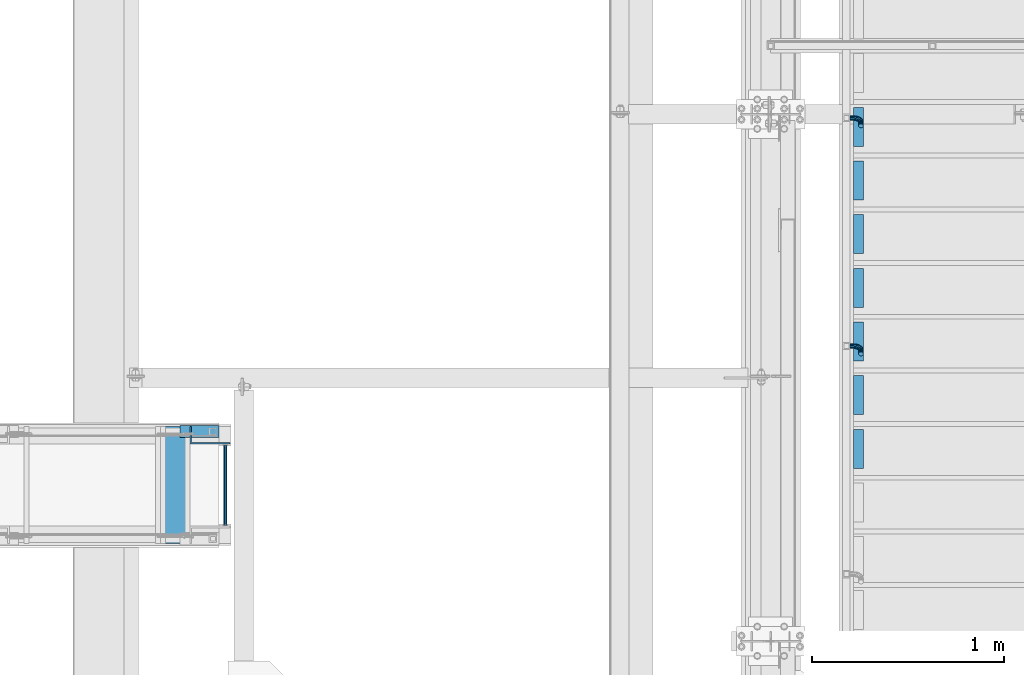
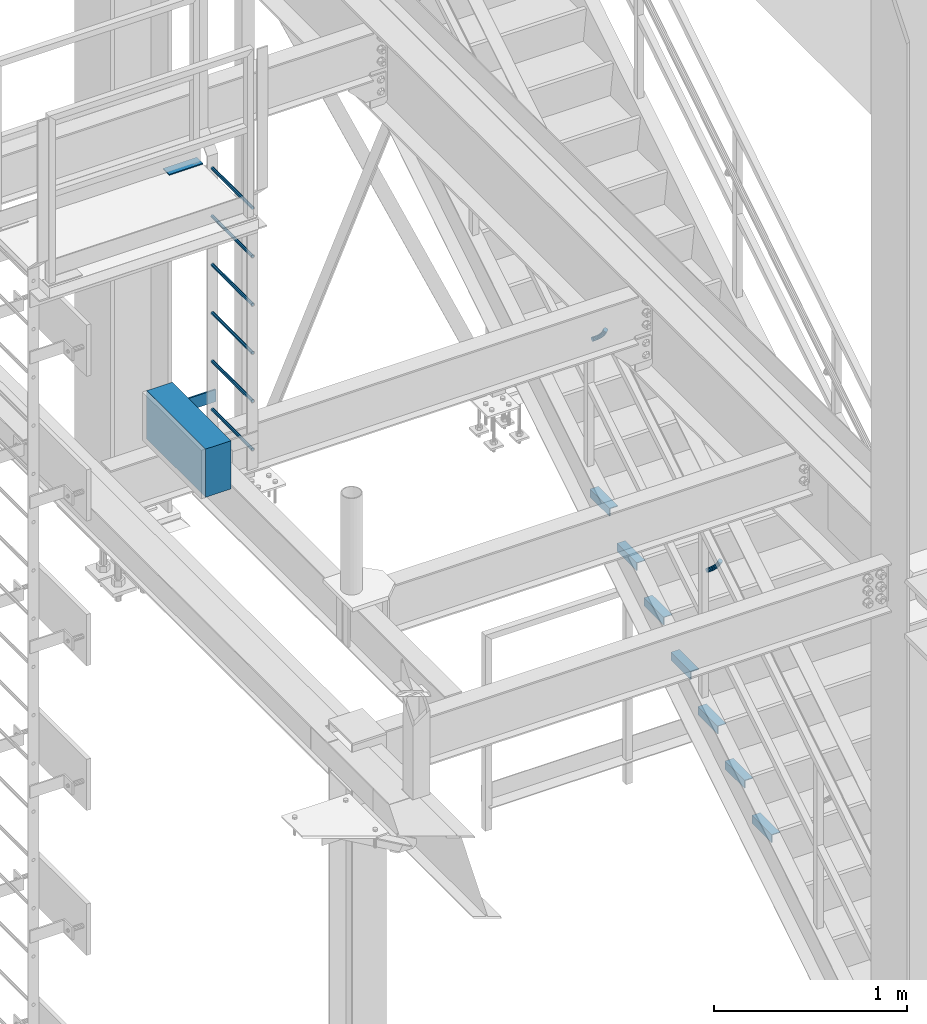
# One storey, part 2016 of 3843: 18 beams, 5 elements without a shape of their own.
"""IFC2X3 building model written with IfcOpenShell, lengths in millimetres."""

from ifc_helpers import new_model, si_unit, frame, origin_with_axes, place, context, subcontext, project, spatial, faceted_brep, material, type_object, element, aggregate, save


model = new_model("IFC2X3")

# Units and contexts
model_context = context("Model", 3, precision=1e-05, world=origin_with_axes())
body_context = subcontext(model_context, "Body", "Model", "MODEL_VIEW")
ifc_project = project(units=[si_unit("LENGTHUNIT", "METRE", prefix="MILLI"), si_unit("AREAUNIT", "SQUARE_METRE"), si_unit("VOLUMEUNIT", "CUBIC_METRE"), si_unit("MASSUNIT", "GRAM", prefix="KILO"), si_unit("TIMEUNIT", "SECOND"), si_unit("PLANEANGLEUNIT", "RADIAN"), si_unit("SOLIDANGLEUNIT", "STERADIAN"), si_unit("THERMODYNAMICTEMPERATUREUNIT", "DEGREE_CELSIUS"), si_unit("LUMINOUSINTENSITYUNIT", "LUMEN")], contexts=[model_context])

# Site, building, storey
site_placement = place(None, origin_with_axes())
site = spatial("IfcSite", under=ifc_project, at=site_placement, CompositionType="ELEMENT")
building_placement = place(site_placement, origin_with_axes())
building = spatial("IfcBuilding", under=site, at=building_placement, Name="Undefined", CompositionType="ELEMENT")
storey_placement = place(building_placement, origin_with_axes())
storey = spatial("IfcBuildingStorey", under=building, at=storey_placement, Name="Undefined", CompositionType="ELEMENT", Elevation=0.0)

# Assembly, beam
assembly_1_placement = place(storey_placement, origin_with_axes())
assembly_1 = element("IfcElementAssembly", 1, at=assembly_1_placement, inside=storey, Name="BEAM", AssemblyPlace="NOTDEFINED", PredefinedType="REINFORCEMENT_UNIT")
ifc_material_1 = material(Name="CONCRETE/5000")
beam_type_1 = type_object("IfcBeamType", PredefinedType="NOTDEFINED")
beam_1_placement = place(assembly_1_placement, frame((33476.6950414921, 27495.4999999999, 35255.2009490967), z_axis=(0.0, 0.0, 1.0), x_axis=(0.0, 1.0, 0.0)))
beam_1 = element("IfcBeam", 2, at=beam_1_placement, type_object=beam_type_1, material=ifc_material_1, Name="BEAM", context=body_context, shape_type="Brep", body=[
    faceted_brep([(0.0, 76.1999999999971, -152.400000000001), (0.0, 76.1999999999971, 152.400000000001), (609.599999999507, 76.1999999999971, 152.400000000001), (609.599999999507, 76.1999999999971, -152.400000000001), (0.0, -76.1999999999971, 152.400000000001), (609.599999999507, -76.1999999999971, 152.400000000001), (0.0, -76.1999999999971, -152.400000000001), (609.599999999507, -76.1999999999971, -152.400000000001)], [[[0, 1, 2, 3]], [[1, 4, 5, 2]], [[4, 6, 7, 5]], [[6, 0, 3, 7]], [[5, 7, 3, 2]], [[6, 4, 1, 0]]]),
])
aggregate(assembly_1, [beam_1])

assembly_2_placement = place(storey_placement, origin_with_axes())
assembly_2 = element("IfcElementAssembly", 3, at=assembly_2_placement, inside=storey, Name="LADDER", AssemblyPlace="NOTDEFINED", PredefinedType="RIGID_FRAME")
ifc_material_2 = material(Name="STEEL/A36")
beam_type_2 = type_object("IfcBeamType", PredefinedType="NOTDEFINED")
beam_2_placement = place(assembly_2_placement, frame((33761.4528544921, 28017.7874999999, 35306.0009490967), z_axis=(0.0, 0.0, 1.0), x_axis=(-1.0, 0.0, 0.0)))
beam_2 = element("IfcBeam", 4, at=beam_2_placement, type_object=beam_type_2, material=ifc_material_2, Name="BENT_PLATE", context=body_context, shape_type="Brep", body=[
    faceted_brep([(0.0, -4.76250000000073, -38.0999999999985), (0.0, -4.76250000000073, 38.0999999999985), (0.0, 4.76250000000073, 38.0999999999985), (0.0, 4.76250000000073, -38.0999999999985), (208.557813000007, 4.76249999999345, 38.0999999999985), (208.557813000007, 4.76249999999345, -38.0999999999985), (199.032813000013, -4.762500000008, -38.0999999999985), (199.032813000013, -4.762500000008, 38.0999999999985), (208.557813000007, -87.3124999995016, 38.0999999999985), (208.557813000007, -87.3124999995016, -38.0999999999985), (199.032813000013, -87.3124999995016, 38.0999999999985), (199.032813000013, -87.3124999995016, -38.0999999999985)], [[[0, 1, 2, 3]], [[3, 2, 4, 5]], [[1, 0, 6, 7]], [[5, 4, 8, 9]], [[4, 2, 1, 7, 10, 8]], [[7, 6, 11, 10]], [[6, 0, 3, 5, 9, 11]], [[10, 11, 9, 8]]]),
])

# Assembly, beams
assembly_3_placement = place(storey_placement, origin_with_axes())
assembly_3 = element("IfcElementAssembly", 5, at=assembly_3_placement, inside=storey, Name="STAIR", AssemblyPlace="NOTDEFINED", PredefinedType="RIGID_FRAME")
beam_type_3 = type_object("IfcBeamType", Name="L2X2X3/16", PredefinedType="NOTDEFINED")
beam_3_placement = place(assembly_3_placement, frame((37033.1999999894, 29563.5169176273, 32490.6821428628), z_axis=(1.0, 0.0, 0.0), x_axis=(0.0, 1.0, 0.0)))
beam_3 = element("IfcBeam", 6, at=beam_3_placement, type_object=beam_type_3, material=ifc_material_2, Name="ANGLE", ObjectType="L2X2X3/16", context=body_context, shape_type="Brep", body=[
    faceted_brep([(0.0, 25.4000000000015, -25.4000000000015), (0.0, 25.4000000000015, 25.4000000000015), (203.199999999997, 25.4000000000015, 25.4000000000015), (203.199999999997, 25.4000000000015, -25.4000000000015), (0.0, 20.6375000000007, 25.4000000000015), (203.199999999997, 20.6375000000007, 25.4000000000015), (0.0, 20.6375000000007, -20.6375000000007), (203.199999999997, 20.6375000000007, -20.6375000000007), (0.0, -25.4000000000015, -20.6375000000007), (203.199999999997, -25.4000000000015, -20.6375000000007), (0.0, -25.4000000000015, -25.4000000000015), (203.199999999997, -25.4000000000015, -25.4000000000015)], [[[0, 1, 2, 3]], [[1, 4, 5, 2]], [[4, 6, 7, 5]], [[6, 8, 9, 7]], [[8, 10, 11, 9]], [[10, 0, 3, 11]], [[5, 7, 9, 11, 3, 2]], [[10, 8, 6, 4, 1, 0]]]),
])
beam_4_placement = place(assembly_3_placement, frame((37033.1999999894, 29284.1169176273, 32316.5107142914), z_axis=(1.0, 0.0, 0.0), x_axis=(0.0, 1.0, 0.0)))
beam_4 = element("IfcBeam", 7, at=beam_4_placement, type_object=beam_type_3, material=ifc_material_2, Name="ANGLE", ObjectType="L2X2X3/16", context=body_context, shape_type="Brep", body=[
    faceted_brep([(0.0, 25.4000000000015, -25.4000000000015), (0.0, 25.4000000000015, 25.4000000000015), (203.199999999997, 25.4000000000015, 25.4000000000015), (203.199999999997, 25.4000000000015, -25.4000000000015), (0.0, 20.6375000000007, 25.4000000000015), (203.199999999997, 20.6375000000007, 25.4000000000015), (0.0, 20.6375000000007, -20.6375000000007), (203.199999999997, 20.6375000000007, -20.6375000000007), (0.0, -25.4000000000015, -20.6375000000007), (203.199999999997, -25.4000000000015, -20.6375000000007), (0.0, -25.4000000000015, -25.4000000000015), (203.199999999997, -25.4000000000015, -25.4000000000015)], [[[0, 1, 2, 3]], [[1, 4, 5, 2]], [[4, 6, 7, 5]], [[6, 8, 9, 7]], [[8, 10, 11, 9]], [[10, 0, 3, 11]], [[5, 7, 9, 11, 3, 2]], [[10, 8, 6, 4, 1, 0]]]),
])
beam_5_placement = place(assembly_3_placement, frame((37033.1999999894, 29004.7169176273, 32142.3392857199), z_axis=(1.0, 0.0, 0.0), x_axis=(0.0, 1.0, 0.0)))
beam_5 = element("IfcBeam", 8, at=beam_5_placement, type_object=beam_type_3, material=ifc_material_2, Name="ANGLE", ObjectType="L2X2X3/16", context=body_context, shape_type="Brep", body=[
    faceted_brep([(0.0, 25.4000000000015, -25.4000000000015), (0.0, 25.4000000000015, 25.4000000000015), (203.199999999997, 25.4000000000015, 25.4000000000015), (203.199999999997, 25.4000000000015, -25.4000000000015), (0.0, 20.6375000000007, 25.4000000000015), (203.199999999997, 20.6375000000007, 25.4000000000015), (0.0, 20.6375000000007, -20.6375000000007), (203.199999999997, 20.6375000000007, -20.6375000000007), (0.0, -25.4000000000015, -20.6375000000007), (203.199999999997, -25.4000000000015, -20.6375000000007), (0.0, -25.4000000000015, -25.4000000000015), (203.199999999997, -25.4000000000015, -25.4000000000015)], [[[0, 1, 2, 3]], [[1, 4, 5, 2]], [[4, 6, 7, 5]], [[6, 8, 9, 7]], [[8, 10, 11, 9]], [[10, 0, 3, 11]], [[5, 7, 9, 11, 3, 2]], [[10, 8, 6, 4, 1, 0]]]),
])
beam_6_placement = place(assembly_3_placement, frame((37033.1999999894, 28725.3169176272, 31968.1678571485), z_axis=(1.0, 0.0, 0.0), x_axis=(0.0, 1.0, 0.0)))
beam_6 = element("IfcBeam", 9, at=beam_6_placement, type_object=beam_type_3, material=ifc_material_2, Name="ANGLE", ObjectType="L2X2X3/16", context=body_context, shape_type="Brep", body=[
    faceted_brep([(0.0, 25.4000000000015, -25.4000000000015), (0.0, 25.4000000000015, 25.4000000000015), (203.199999999997, 25.4000000000015, 25.4000000000015), (203.199999999997, 25.4000000000015, -25.4000000000015), (0.0, 20.6375000000007, 25.4000000000015), (203.199999999997, 20.6375000000007, 25.4000000000015), (0.0, 20.6375000000007, -20.6375000000007), (203.199999999997, 20.6375000000007, -20.6375000000007), (0.0, -25.4000000000015, -20.6375000000007), (203.199999999997, -25.4000000000015, -20.6375000000007), (0.0, -25.4000000000015, -25.4000000000015), (203.199999999997, -25.4000000000015, -25.4000000000015)], [[[0, 1, 2, 3]], [[1, 4, 5, 2]], [[4, 6, 7, 5]], [[6, 8, 9, 7]], [[8, 10, 11, 9]], [[10, 0, 3, 11]], [[5, 7, 9, 11, 3, 2]], [[10, 8, 6, 4, 1, 0]]]),
])
beam_7_placement = place(assembly_3_placement, frame((37033.1999999894, 28445.9169176272, 31793.9964285771), z_axis=(1.0, 0.0, 0.0), x_axis=(0.0, 1.0, 0.0)))
beam_7 = element("IfcBeam", 10, at=beam_7_placement, type_object=beam_type_3, material=ifc_material_2, Name="ANGLE", ObjectType="L2X2X3/16", context=body_context, shape_type="Brep", body=[
    faceted_brep([(0.0, 25.4000000000015, -25.4000000000015), (0.0, 25.4000000000015, 25.4000000000015), (203.199999999997, 25.4000000000015, 25.4000000000015), (203.199999999997, 25.4000000000015, -25.4000000000015), (0.0, 20.6375000000007, 25.4000000000015), (203.199999999997, 20.6375000000007, 25.4000000000015), (0.0, 20.6375000000007, -20.6375000000007), (203.199999999997, 20.6375000000007, -20.6375000000007), (0.0, -25.4000000000015, -20.6375000000007), (203.199999999997, -25.4000000000015, -20.6375000000007), (0.0, -25.4000000000015, -25.4000000000015), (203.199999999997, -25.4000000000015, -25.4000000000015)], [[[0, 1, 2, 3]], [[1, 4, 5, 2]], [[4, 6, 7, 5]], [[6, 8, 9, 7]], [[8, 10, 11, 9]], [[10, 0, 3, 11]], [[5, 7, 9, 11, 3, 2]], [[10, 8, 6, 4, 1, 0]]]),
])
beam_8_placement = place(assembly_3_placement, frame((37033.1999999894, 28166.5169176272, 31619.8250000057), z_axis=(1.0, 0.0, 0.0), x_axis=(0.0, 1.0, 0.0)))
beam_8 = element("IfcBeam", 11, at=beam_8_placement, type_object=beam_type_3, material=ifc_material_2, Name="ANGLE", ObjectType="L2X2X3/16", context=body_context, shape_type="Brep", body=[
    faceted_brep([(0.0, 25.4000000000015, -25.4000000000015), (0.0, 25.4000000000015, 25.4000000000015), (203.199999999997, 25.4000000000015, 25.4000000000015), (203.199999999997, 25.4000000000015, -25.4000000000015), (0.0, 20.6375000000007, 25.4000000000015), (203.199999999997, 20.6375000000007, 25.4000000000015), (0.0, 20.6375000000007, -20.6375000000007), (203.199999999997, 20.6375000000007, -20.6375000000007), (0.0, -25.4000000000015, -20.6375000000007), (203.199999999997, -25.4000000000015, -20.6375000000007), (0.0, -25.4000000000015, -25.4000000000015), (203.199999999997, -25.4000000000015, -25.4000000000015)], [[[0, 1, 2, 3]], [[1, 4, 5, 2]], [[4, 6, 7, 5]], [[6, 8, 9, 7]], [[8, 10, 11, 9]], [[10, 0, 3, 11]], [[5, 7, 9, 11, 3, 2]], [[10, 8, 6, 4, 1, 0]]]),
])
beam_9_placement = place(assembly_3_placement, frame((37033.1999999894, 27887.1169176272, 31445.6535714342), z_axis=(1.0, 0.0, 0.0), x_axis=(0.0, 1.0, 0.0)))
beam_9 = element("IfcBeam", 12, at=beam_9_placement, type_object=beam_type_3, material=ifc_material_2, Name="ANGLE", ObjectType="L2X2X3/16", context=body_context, shape_type="Brep", body=[
    faceted_brep([(0.0, 25.4000000000015, -25.4000000000015), (0.0, 25.4000000000015, 25.4000000000015), (203.199999999997, 25.4000000000015, 25.4000000000015), (203.199999999997, 25.4000000000015, -25.4000000000015), (0.0, 20.6375000000007, 25.4000000000015), (203.199999999997, 20.6375000000007, 25.4000000000015), (0.0, 20.6375000000007, -20.6375000000007), (203.199999999997, 20.6375000000007, -20.6375000000007), (0.0, -25.4000000000015, -20.6375000000007), (203.199999999997, -25.4000000000015, -20.6375000000007), (0.0, -25.4000000000015, -25.4000000000015), (203.199999999997, -25.4000000000015, -25.4000000000015)], [[[0, 1, 2, 3]], [[1, 4, 5, 2]], [[4, 6, 7, 5]], [[6, 8, 9, 7]], [[8, 10, 11, 9]], [[10, 0, 3, 11]], [[5, 7, 9, 11, 3, 2]], [[10, 8, 6, 4, 1, 0]]]),
])
aggregate(assembly_3, [beam_3, beam_4, beam_5, beam_6, beam_7, beam_8, beam_9])

# Beam
ifc_material_3 = material(Name="STEEL/A572-50")
beam_type_4 = type_object("IfcBeamType", PredefinedType="NOTDEFINED")
beam_10_placement = place(assembly_2_placement, frame((33736.4390258789, 27590.7499999999, 35231.5155151367), z_axis=(-1.0, 0.0, 0.0), x_axis=(0.0, 1.0, 0.0)))
beam_10 = element("IfcBeam", 13, at=beam_10_placement, type_object=beam_type_4, material=ifc_material_3, Name="RUNG", context=body_context, shape_type="Brep", body=[
    faceted_brep([(0.0, -9.52500000000146, 0.0), (0.0, -6.73519209080405, -6.73519209079677), (419.100000000006, -6.73519209080405, -6.73519209079677), (419.100000000006, -9.52500000000146, 0.0), (2.95075507493764e-12, 2.91322521661641e-12, -9.52499961853027), (419.100000000006, 0.0, -9.52499999999418), (0.0, 6.73519209080405, -6.73519209079677), (419.100000000006, 6.73519209080405, -6.73519209079677), (0.0, 9.52500000000146, 0.0), (419.100000000006, 9.52500000000146, 0.0), (0.0, 6.73519209080405, 6.73519209079677), (419.100000000006, 6.73519209080405, 6.73519209079677), (-9.87109982941227e-13, 2.91322521661641e-12, 9.52499961853027), (419.100000000006, 0.0, 9.52499999999418), (0.0, -6.73519209080405, 6.73519209079677), (419.100000000006, -6.73519209080405, 6.73519209079677)], [[[0, 1, 2, 3]], [[1, 4, 5, 2]], [[4, 6, 7, 5]], [[6, 8, 9, 7]], [[8, 10, 11, 9]], [[10, 12, 13, 11]], [[12, 14, 15, 13]], [[14, 0, 3, 15]], [[5, 7, 9, 11, 13, 15, 3, 2]], [[14, 12, 10, 8, 6, 4, 1, 0]]]),
])

beam_11_placement = place(assembly_2_placement, frame((33736.4390258789, 27590.7499999999, 35841.1155151367), z_axis=(-1.0, 0.0, 0.0), x_axis=(0.0, 1.0, 0.0)))
beam_11 = element("IfcBeam", 14, at=beam_11_placement, type_object=beam_type_4, material=ifc_material_3, Name="RUNG", context=body_context, shape_type="Brep", body=[
    faceted_brep([(0.0, -9.52500000000146, 0.0), (0.0, -6.73519209080405, -6.73519209079677), (419.100000000006, -6.73519209080405, -6.73519209079677), (419.100000000006, -9.52500000000146, 0.0), (2.95075507493764e-12, 2.91322521661641e-12, -9.52499961853027), (419.100000000006, 0.0, -9.52499999999418), (0.0, 6.73519209080405, -6.73519209079677), (419.100000000006, 6.73519209080405, -6.73519209079677), (0.0, 9.52500000000146, 0.0), (419.100000000006, 9.52500000000146, 0.0), (0.0, 6.73519209080405, 6.73519209079677), (419.100000000006, 6.73519209080405, 6.73519209079677), (-9.87109982941227e-13, 2.91322521661641e-12, 9.52499961853027), (419.100000000006, 0.0, 9.52499999999418), (0.0, -6.73519209080405, 6.73519209079677), (419.100000000006, -6.73519209080405, 6.73519209079677)], [[[0, 1, 2, 3]], [[1, 4, 5, 2]], [[4, 6, 7, 5]], [[6, 8, 9, 7]], [[8, 10, 11, 9]], [[10, 12, 13, 11]], [[12, 14, 15, 13]], [[14, 0, 3, 15]], [[5, 7, 9, 11, 13, 15, 3, 2]], [[14, 12, 10, 8, 6, 4, 1, 0]]]),
])

beam_12_placement = place(assembly_2_placement, frame((33736.4390258789, 27590.7499999999, 35536.3155151367), z_axis=(-1.0, 0.0, 0.0), x_axis=(0.0, 1.0, 0.0)))
beam_12 = element("IfcBeam", 15, at=beam_12_placement, type_object=beam_type_4, material=ifc_material_3, Name="RUNG", context=body_context, shape_type="Brep", body=[
    faceted_brep([(0.0, -9.52500000000146, 0.0), (0.0, -6.73519209080405, -6.73519209079677), (419.100000000006, -6.73519209080405, -6.73519209079677), (419.100000000006, -9.52500000000146, 0.0), (2.95075507493764e-12, 2.91322521661641e-12, -9.52499961853027), (419.100000000006, 0.0, -9.52499999999418), (0.0, 6.73519209080405, -6.73519209079677), (419.100000000006, 6.73519209080405, -6.73519209079677), (0.0, 9.52500000000146, 0.0), (419.100000000006, 9.52500000000146, 0.0), (0.0, 6.73519209080405, 6.73519209079677), (419.100000000006, 6.73519209080405, 6.73519209079677), (-9.87109982941227e-13, 2.91322521661641e-12, 9.52499961853027), (419.100000000006, 0.0, 9.52499999999418), (0.0, -6.73519209080405, 6.73519209079677), (419.100000000006, -6.73519209080405, 6.73519209079677)], [[[0, 1, 2, 3]], [[1, 4, 5, 2]], [[4, 6, 7, 5]], [[6, 8, 9, 7]], [[8, 10, 11, 9]], [[10, 12, 13, 11]], [[12, 14, 15, 13]], [[14, 0, 3, 15]], [[5, 7, 9, 11, 13, 15, 3, 2]], [[14, 12, 10, 8, 6, 4, 1, 0]]]),
])

beam_13_placement = place(assembly_2_placement, frame((33736.4390258789, 27590.7499999999, 36145.9155151367), z_axis=(-1.0, 0.0, 0.0), x_axis=(0.0, 1.0, 0.0)))
beam_13 = element("IfcBeam", 16, at=beam_13_placement, type_object=beam_type_4, material=ifc_material_3, Name="RUNG", context=body_context, shape_type="Brep", body=[
    faceted_brep([(0.0, -9.52500000000146, 0.0), (0.0, -6.73519209080405, -6.73519209079677), (419.100000000006, -6.73519209080405, -6.73519209079677), (419.100000000006, -9.52500000000146, 0.0), (2.95075507493764e-12, 2.91322521661641e-12, -9.52499961853027), (419.100000000006, 0.0, -9.52499999999418), (0.0, 6.73519209080405, -6.73519209079677), (419.100000000006, 6.73519209080405, -6.73519209079677), (0.0, 9.52500000000146, 0.0), (419.100000000006, 9.52500000000146, 0.0), (0.0, 6.73519209080405, 6.73519209079677), (419.100000000006, 6.73519209080405, 6.73519209079677), (-9.87109982941227e-13, 2.91322521661641e-12, 9.52499961853027), (419.100000000006, 0.0, 9.52499999999418), (0.0, -6.73519209080405, 6.73519209079677), (419.100000000006, -6.73519209080405, 6.73519209079677)], [[[0, 1, 2, 3]], [[1, 4, 5, 2]], [[4, 6, 7, 5]], [[6, 8, 9, 7]], [[8, 10, 11, 9]], [[10, 12, 13, 11]], [[12, 14, 15, 13]], [[14, 0, 3, 15]], [[5, 7, 9, 11, 13, 15, 3, 2]], [[14, 12, 10, 8, 6, 4, 1, 0]]]),
])

beam_14_placement = place(assembly_2_placement, frame((33736.4390258789, 27590.7499999999, 36450.7155151367), z_axis=(-1.0, 0.0, 0.0), x_axis=(0.0, 1.0, 0.0)))
beam_14 = element("IfcBeam", 17, at=beam_14_placement, type_object=beam_type_4, material=ifc_material_3, Name="RUNG", context=body_context, shape_type="Brep", body=[
    faceted_brep([(0.0, -9.52500000000146, 0.0), (0.0, -6.73519209080405, -6.73519209079677), (419.100000000006, -6.73519209080405, -6.73519209079677), (419.100000000006, -9.52500000000146, 0.0), (2.95075507493764e-12, 2.91322521661641e-12, -9.52499961853027), (419.100000000006, 0.0, -9.52499999999418), (0.0, 6.73519209080405, -6.73519209079677), (419.100000000006, 6.73519209080405, -6.73519209079677), (0.0, 9.52500000000146, 0.0), (419.100000000006, 9.52500000000146, 0.0), (0.0, 6.73519209080405, 6.73519209079677), (419.100000000006, 6.73519209080405, 6.73519209079677), (-9.87109982941227e-13, 2.91322521661641e-12, 9.52499961853027), (419.100000000006, 0.0, 9.52499999999418), (0.0, -6.73519209080405, 6.73519209079677), (419.100000000006, -6.73519209080405, 6.73519209079677)], [[[0, 1, 2, 3]], [[1, 4, 5, 2]], [[4, 6, 7, 5]], [[6, 8, 9, 7]], [[8, 10, 11, 9]], [[10, 12, 13, 11]], [[12, 14, 15, 13]], [[14, 0, 3, 15]], [[5, 7, 9, 11, 13, 15, 3, 2]], [[14, 12, 10, 8, 6, 4, 1, 0]]]),
])

beam_15_placement = place(assembly_2_placement, frame((33736.4390258789, 27590.7499999999, 36755.5155151367), z_axis=(-1.0, 0.0, 0.0), x_axis=(0.0, 1.0, 0.0)))
beam_15 = element("IfcBeam", 18, at=beam_15_placement, type_object=beam_type_4, material=ifc_material_3, Name="RUNG", context=body_context, shape_type="Brep", body=[
    faceted_brep([(0.0, -9.52500000000146, 0.0), (0.0, -6.73519209080405, -6.73519209079677), (419.100000000006, -6.73519209080405, -6.73519209079677), (419.100000000006, -9.52500000000146, 0.0), (2.95075507493764e-12, 2.91322521661641e-12, -9.52499961853027), (419.100000000006, 0.0, -9.52499999999418), (0.0, 6.73519209080405, -6.73519209079677), (419.100000000006, 6.73519209080405, -6.73519209079677), (0.0, 9.52500000000146, 0.0), (419.100000000006, 9.52500000000146, 0.0), (0.0, 6.73519209080405, 6.73519209079677), (419.100000000006, 6.73519209080405, 6.73519209079677), (-9.87109982941227e-13, 2.91322521661641e-12, 9.52499961853027), (419.100000000006, 0.0, 9.52499999999418), (0.0, -6.73519209080405, 6.73519209079677), (419.100000000006, -6.73519209080405, 6.73519209079677)], [[[0, 1, 2, 3]], [[1, 4, 5, 2]], [[4, 6, 7, 5]], [[6, 8, 9, 7]], [[8, 10, 11, 9]], [[10, 12, 13, 11]], [[12, 14, 15, 13]], [[14, 0, 3, 15]], [[5, 7, 9, 11, 13, 15, 3, 2]], [[14, 12, 10, 8, 6, 4, 1, 0]]]),
])

aggregate(assembly_2, [beam_2, beam_10, beam_11, beam_12, beam_13, beam_14, beam_15])

# Assembly, beam
assembly_4_placement = place(storey_placement, origin_with_axes())
assembly_4 = element("IfcElementAssembly", 19, at=assembly_4_placement, inside=storey, Name="RAIL", AssemblyPlace="NOTDEFINED", PredefinedType="RIGID_FRAME")
beam_type_5 = type_object("IfcBeamType", PredefinedType="NOTDEFINED")
beam_16_placement = place(assembly_4_placement, frame((33704.6093748092, 28079.6999999999, 36768.7510559082), z_axis=(0.0, -1.0, 0.0), x_axis=(-1.0, 0.0, 0.0)))
beam_16 = element("IfcBeam", 20, at=beam_16_placement, type_object=beam_type_5, material=ifc_material_2, context=body_context, shape_type="Brep", body=[
    faceted_brep([(0.0, 3.17500000000291, -31.75), (0.0, 3.17500000000291, 31.75), (203.199998088516, 3.17500000000291, 31.75), (203.199998088516, 3.17500000000291, -31.75), (0.0, -3.17500000000291, 31.75), (203.199998088516, -3.17500000000291, 31.75), (0.0, -3.17500000000291, -31.75), (203.199998088516, -3.17500000000291, -31.75)], [[[0, 1, 2, 3]], [[1, 4, 5, 2]], [[4, 6, 7, 5]], [[6, 0, 3, 7]], [[5, 7, 3, 2]], [[6, 4, 1, 0]]]),
])
aggregate(assembly_4, [beam_16])

# Assembly, beams
assembly_5_placement = place(storey_placement, origin_with_axes())
assembly_5 = element("IfcElementAssembly", 21, at=assembly_5_placement, inside=storey, Name="RAIL", AssemblyPlace="NOTDEFINED", PredefinedType="RIGID_FRAME")
beam_type_6 = type_object("IfcBeamType", PredefinedType="NOTDEFINED")
beam_17_placement = place(assembly_5_placement, frame((36988.7499999524, 29710.4372641599, 33502.0882601577), z_axis=(0.0, -0.848616882600525, -0.529007926750977), x_axis=(1.0, 0.0, 0.0)))
beam_17 = element("IfcBeam", 22, at=beam_17_placement, type_object=beam_type_6, material=ifc_material_2, Name="BRACKET ARM", context=body_context, shape_type="Brep", body=[
    faceted_brep([(0.0, -12.6999999999971, 0.0), (0.0, -10.9985226280696, -6.34999999999854), (19.0500015258731, -10.9985226280623, -6.34999999999854), (19.0500015258731, -12.6999999999971, -6.33008312433958e-10), (0.0, -6.35000000000582, -10.9985226280623), (19.0500015258731, -6.34999999999854, -10.9985226280623), (0.0, 0.0, -12.6999999999971), (19.0500015258731, 0.0, -12.6999999999971), (0.0, 6.35000000000582, -10.9985226280623), (19.0500015258731, 6.34999999999854, -10.9985226280623), (0.0, 10.9985226280696, -6.34999999999854), (19.0500015258731, 10.9985226280623, -6.34999999999854), (0.0, 12.6999999999971, 0.0), (19.0500015258731, 12.6999999999971, 0.0), (0.0, 10.9985226280696, 6.34999999999854), (19.0500015258731, 10.9985226280623, 6.34999999999854), (0.0, 6.35000000000582, 10.9985226280623), (19.0500015258731, 6.34999999999854, 10.9985226280623), (0.0, 0.0, 12.6999999999971), (19.0500015258731, 0.0, 12.6999999999971), (0.0, -6.35000000000582, 10.9985226280623), (19.0500015258731, -6.34999999999854, 10.9985226280623), (0.0, -10.9985226280696, 6.34999999999854), (19.0500015258731, -10.9985226280623, 6.34999999999854), (38.4903193060891, -8.8330803677236, -3.34694050252438e-10), (37.8391921052389, -7.26112024908798, 6.34999999974389), (36.0602795104642, -2.96644533684594, 10.9985226280041), (33.6302397149266, 2.90018969451194, 12.7000000002226), (31.2001999194181, 8.76682472604443, 10.9985226285644), (29.4212873247307, 13.061499638774, 6.35000000070431), (28.7701601240115, 14.6334597580644, 7.78527464717627e-10), (29.4212873248762, 13.0614996394288, -6.34999999929278), (31.2001999196509, 8.76682472718676, -10.9985226275603), (33.6302397151885, 2.90018969582889, -12.6999999997788), (36.0602795106824, -2.96644533571089, -10.9985226281206), (37.8391921053699, -7.26112024843314, -6.35000000026048), (53.7678987435793, 3.38210125690239, -6.3499999994383), (54.9710249311902, 2.17897506880399, 5.0931703299284e-10), (50.4808968708676, 6.66910312997061, -10.9985226273784), (45.9907688103704, 11.1592311906061, -12.6999999991458), (41.5006407498004, 15.6493592510378, -10.9985226270364), (38.213638876914, 18.9363611235749, -6.34999999884167), (37.0105126890558, 20.1394873109457, 1.20053300634027e-09), (38.2136388766667, 18.9363611228473, 6.35000000115542), (41.5006407493784, 15.6493592497718, 10.9985226290883), (45.9907688098756, 11.1592311891436, 12.7000000008557), (50.4808968704456, 6.66910312870459, 10.9985226287463), (53.7678987433319, 3.38210125617479, 6.35000000055879), (64.4111202489148, 19.3108078951118, -6.34999999821594), (65.9830803677178, 18.6596806939051, 1.77533365786076e-09), (60.1164453365491, 21.0897204901557, -10.9985226262725), (54.2498103051475, 23.5197602857806, -12.6999999981927), (48.3831752736587, 25.9498000811873, -10.9985226262434), (44.0885003610601, 27.7287126756128, -6.34999999817228), (42.516540241937, 28.3798398759754, 1.83354131877422e-09), (44.08850036074, 27.7287126747688, 6.35000000183209), (48.3831752731057, 25.9498000797321, 10.9985226298813), (54.2498103045073, 23.5197602840999, 12.7000000018088), (60.1164453359961, 21.0897204886933, 10.9985226298522), (64.4111202485947, 19.3108078942678, 6.35000000178115), (68.1485226282239, 38.0999984746086, -6.3499999967753), (69.8499999999913, 38.0999984741211, 2.92493496090174e-09), (63.500000000291, 38.0999984749651, -10.9985226249628), (57.1500000003434, 38.0999984750961, -12.6999999970722), (50.8000000002939, 38.0999984749651, -10.998522625312), (46.1514773720992, 38.0999984746086, -6.34999999737192), (44.4499999999971, 38.0999984741211, 2.58296495303512e-09), (46.1514773717645, 38.0999984736336, 6.35000000262517), (50.7999999996973, 38.0999984732771, 10.9985226308127), (57.1499999996449, 38.0999984731461, 12.700000002922), (63.4999999996944, 38.0999984732771, 10.9985226311619), (68.1485226278892, 38.0999984736336, 6.35000000322179), (68.1485226280638, 76.2000000002372, -6.34999999414867), (69.8499999999913, 76.199999999757, 5.84986992180347e-09), (63.5, 76.200000000601, -10.9985226222125), (57.1499999999942, 76.2000000007247, -12.6999999941472), (50.7999999999884, 76.200000000601, -10.9985226222125), (46.1514773719246, 76.2000000002372, -6.34999999414867), (44.4499999999971, 76.199999999757, 5.84986992180347e-09), (46.1514773719246, 76.1999999992695, 6.35000000584841), (50.7999999999884, 76.1999999989057, 10.9985226339122), (57.1499999999942, 76.199999998782, 12.700000005847), (63.5, 76.1999999989057, 10.9985226339122), (68.1485226280638, 76.1999999992695, 6.35000000584841)], [[[0, 1, 2, 3]], [[1, 4, 5, 2]], [[4, 6, 7, 5]], [[6, 8, 9, 7]], [[8, 10, 11, 9]], [[10, 12, 13, 11]], [[12, 14, 15, 13]], [[14, 16, 17, 15]], [[16, 18, 19, 17]], [[18, 20, 21, 19]], [[20, 22, 23, 21]], [[22, 0, 3, 23]], [[22, 20, 18, 16, 14, 12, 10, 8, 6, 4, 1, 0]], [[23, 3, 24, 25]], [[21, 23, 25, 26]], [[19, 21, 26, 27]], [[17, 19, 27, 28]], [[15, 17, 28, 29]], [[13, 15, 29, 30]], [[11, 13, 30, 31]], [[9, 11, 31, 32]], [[7, 9, 32, 33]], [[5, 7, 33, 34]], [[2, 5, 34, 35]], [[3, 2, 35, 24]], [[35, 36, 37, 24]], [[34, 38, 36, 35]], [[33, 39, 38, 34]], [[32, 40, 39, 33]], [[31, 41, 40, 32]], [[30, 42, 41, 31]], [[29, 43, 42, 30]], [[28, 44, 43, 29]], [[27, 45, 44, 28]], [[26, 46, 45, 27]], [[25, 47, 46, 26]], [[24, 37, 47, 25]], [[36, 48, 49, 37]], [[38, 50, 48, 36]], [[39, 51, 50, 38]], [[40, 52, 51, 39]], [[41, 53, 52, 40]], [[42, 54, 53, 41]], [[43, 55, 54, 42]], [[44, 56, 55, 43]], [[45, 57, 56, 44]], [[46, 58, 57, 45]], [[47, 59, 58, 46]], [[37, 49, 59, 47]], [[48, 60, 61, 49]], [[50, 62, 60, 48]], [[51, 63, 62, 50]], [[52, 64, 63, 51]], [[53, 65, 64, 52]], [[54, 66, 65, 53]], [[55, 67, 66, 54]], [[56, 68, 67, 55]], [[57, 69, 68, 56]], [[58, 70, 69, 57]], [[59, 71, 70, 58]], [[49, 61, 71, 59]], [[61, 60, 72, 73]], [[60, 62, 74, 72]], [[62, 63, 75, 74]], [[63, 64, 76, 75]], [[64, 65, 77, 76]], [[65, 66, 78, 77]], [[66, 67, 79, 78]], [[67, 68, 80, 79]], [[68, 69, 81, 80]], [[69, 70, 82, 81]], [[70, 71, 83, 82]], [[71, 61, 73, 83]], [[74, 75, 76, 77, 78, 79, 80, 81, 82, 83, 73, 72]]]),
])
beam_18_placement = place(assembly_5_placement, frame((36988.7499999524, 28523.5722998905, 32762.2243863286), z_axis=(0.0, -0.848616882600525, -0.529007926750977), x_axis=(1.0, 0.0, 0.0)))
beam_18 = element("IfcBeam", 23, at=beam_18_placement, type_object=beam_type_6, material=ifc_material_2, Name="BRACKET ARM", context=body_context, shape_type="Brep", body=[
    faceted_brep([(0.0, -12.6999999999971, 0.0), (0.0, -10.9985226280696, -6.34999999999854), (19.0500015258731, -10.9985226280623, -6.34999999999854), (19.0500015258731, -12.6999999999971, -6.33008312433958e-10), (0.0, -6.35000000000582, -10.9985226280623), (19.0500015258731, -6.34999999999854, -10.9985226280623), (0.0, 0.0, -12.6999999999971), (19.0500015258731, 0.0, -12.6999999999971), (0.0, 6.35000000000582, -10.9985226280623), (19.0500015258731, 6.34999999999854, -10.9985226280623), (0.0, 10.9985226280696, -6.34999999999854), (19.0500015258731, 10.9985226280623, -6.34999999999854), (0.0, 12.6999999999971, 0.0), (19.0500015258731, 12.6999999999971, 0.0), (0.0, 10.9985226280696, 6.34999999999854), (19.0500015258731, 10.9985226280623, 6.34999999999854), (0.0, 6.35000000000582, 10.9985226280623), (19.0500015258731, 6.34999999999854, 10.9985226280623), (0.0, 0.0, 12.6999999999971), (19.0500015258731, 0.0, 12.6999999999971), (0.0, -6.35000000000582, 10.9985226280623), (19.0500015258731, -6.34999999999854, 10.9985226280623), (0.0, -10.9985226280696, 6.34999999999854), (19.0500015258731, -10.9985226280623, 6.34999999999854), (38.4903193060891, -8.8330803677236, -3.34694050252438e-10), (37.8391921052389, -7.26112024908798, 6.34999999974389), (36.0602795104642, -2.96644533684594, 10.9985226280041), (33.6302397149266, 2.90018969451194, 12.7000000002226), (31.2001999194181, 8.76682472604443, 10.9985226285644), (29.4212873247307, 13.061499638774, 6.35000000070431), (28.7701601240115, 14.6334597580644, 7.78527464717627e-10), (29.4212873248762, 13.0614996394288, -6.34999999929278), (31.2001999196509, 8.76682472718676, -10.9985226275603), (33.6302397151885, 2.90018969582889, -12.6999999997788), (36.0602795106824, -2.96644533571089, -10.9985226281206), (37.8391921053699, -7.26112024843314, -6.35000000026048), (53.7678987435793, 3.38210125690239, -6.3499999994383), (54.9710249311902, 2.17897506880399, 5.0931703299284e-10), (50.4808968708676, 6.66910312997061, -10.9985226273784), (45.9907688103704, 11.1592311906061, -12.6999999991458), (41.5006407498004, 15.6493592510378, -10.9985226270364), (38.213638876914, 18.9363611235749, -6.34999999884167), (37.0105126890558, 20.1394873109457, 1.20053300634027e-09), (38.2136388766667, 18.9363611228473, 6.35000000115542), (41.5006407493784, 15.6493592497718, 10.9985226290883), (45.9907688098756, 11.1592311891436, 12.7000000008557), (50.4808968704456, 6.66910312870459, 10.9985226287463), (53.7678987433319, 3.38210125617479, 6.35000000055879), (64.4111202489148, 19.3108078951118, -6.34999999821594), (65.9830803677178, 18.6596806939051, 1.77533365786076e-09), (60.1164453365491, 21.0897204901557, -10.9985226262725), (54.2498103051475, 23.5197602857806, -12.6999999981927), (48.3831752736587, 25.9498000811873, -10.9985226262434), (44.0885003610601, 27.7287126756128, -6.34999999817228), (42.516540241937, 28.3798398759754, 1.83354131877422e-09), (44.08850036074, 27.7287126747688, 6.35000000183209), (48.3831752731057, 25.9498000797321, 10.9985226298813), (54.2498103045073, 23.5197602840999, 12.7000000018088), (60.1164453359961, 21.0897204886933, 10.9985226298522), (64.4111202485947, 19.3108078942678, 6.35000000178115), (68.1485226282239, 38.0999984746086, -6.3499999967753), (69.8499999999913, 38.0999984741211, 2.92493496090174e-09), (63.500000000291, 38.0999984749651, -10.9985226249628), (57.1500000003434, 38.0999984750961, -12.6999999970722), (50.8000000002939, 38.0999984749651, -10.998522625312), (46.1514773720992, 38.0999984746086, -6.34999999737192), (44.4499999999971, 38.0999984741211, 2.58296495303512e-09), (46.1514773717645, 38.0999984736336, 6.35000000262517), (50.7999999996973, 38.0999984732771, 10.9985226308127), (57.1499999996449, 38.0999984731461, 12.700000002922), (63.4999999996944, 38.0999984732771, 10.9985226311619), (68.1485226278892, 38.0999984736336, 6.35000000322179), (68.1485226280638, 76.2000000002372, -6.34999999414867), (69.8499999999913, 76.199999999757, 5.84986992180347e-09), (63.5, 76.200000000601, -10.9985226222125), (57.1499999999942, 76.2000000007247, -12.6999999941472), (50.7999999999884, 76.200000000601, -10.9985226222125), (46.1514773719246, 76.2000000002372, -6.34999999414867), (44.4499999999971, 76.199999999757, 5.84986992180347e-09), (46.1514773719246, 76.1999999992695, 6.35000000584841), (50.7999999999884, 76.1999999989057, 10.9985226339122), (57.1499999999942, 76.199999998782, 12.700000005847), (63.5, 76.1999999989057, 10.9985226339122), (68.1485226280638, 76.1999999992695, 6.35000000584841)], [[[0, 1, 2, 3]], [[1, 4, 5, 2]], [[4, 6, 7, 5]], [[6, 8, 9, 7]], [[8, 10, 11, 9]], [[10, 12, 13, 11]], [[12, 14, 15, 13]], [[14, 16, 17, 15]], [[16, 18, 19, 17]], [[18, 20, 21, 19]], [[20, 22, 23, 21]], [[22, 0, 3, 23]], [[22, 20, 18, 16, 14, 12, 10, 8, 6, 4, 1, 0]], [[23, 3, 24, 25]], [[21, 23, 25, 26]], [[19, 21, 26, 27]], [[17, 19, 27, 28]], [[15, 17, 28, 29]], [[13, 15, 29, 30]], [[11, 13, 30, 31]], [[9, 11, 31, 32]], [[7, 9, 32, 33]], [[5, 7, 33, 34]], [[2, 5, 34, 35]], [[3, 2, 35, 24]], [[35, 36, 37, 24]], [[34, 38, 36, 35]], [[33, 39, 38, 34]], [[32, 40, 39, 33]], [[31, 41, 40, 32]], [[30, 42, 41, 31]], [[29, 43, 42, 30]], [[28, 44, 43, 29]], [[27, 45, 44, 28]], [[26, 46, 45, 27]], [[25, 47, 46, 26]], [[24, 37, 47, 25]], [[36, 48, 49, 37]], [[38, 50, 48, 36]], [[39, 51, 50, 38]], [[40, 52, 51, 39]], [[41, 53, 52, 40]], [[42, 54, 53, 41]], [[43, 55, 54, 42]], [[44, 56, 55, 43]], [[45, 57, 56, 44]], [[46, 58, 57, 45]], [[47, 59, 58, 46]], [[37, 49, 59, 47]], [[48, 60, 61, 49]], [[50, 62, 60, 48]], [[51, 63, 62, 50]], [[52, 64, 63, 51]], [[53, 65, 64, 52]], [[54, 66, 65, 53]], [[55, 67, 66, 54]], [[56, 68, 67, 55]], [[57, 69, 68, 56]], [[58, 70, 69, 57]], [[59, 71, 70, 58]], [[49, 61, 71, 59]], [[61, 60, 72, 73]], [[60, 62, 74, 72]], [[62, 63, 75, 74]], [[63, 64, 76, 75]], [[64, 65, 77, 76]], [[65, 66, 78, 77]], [[66, 67, 79, 78]], [[67, 68, 80, 79]], [[68, 69, 81, 80]], [[69, 70, 82, 81]], [[70, 71, 83, 82]], [[71, 61, 73, 83]], [[74, 75, 76, 77, 78, 79, 80, 81, 82, 83, 73, 72]]]),
])
aggregate(assembly_5, [beam_17, beam_18])

save(model, "model.ifc")
